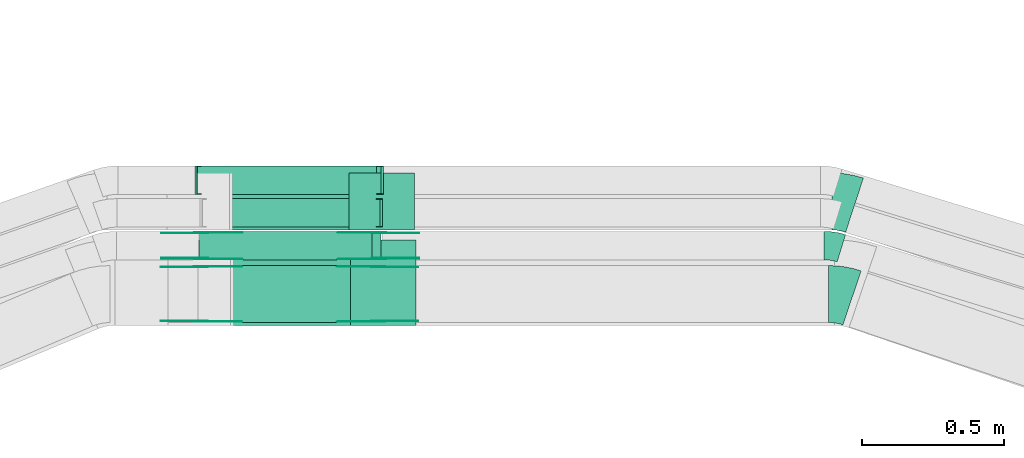
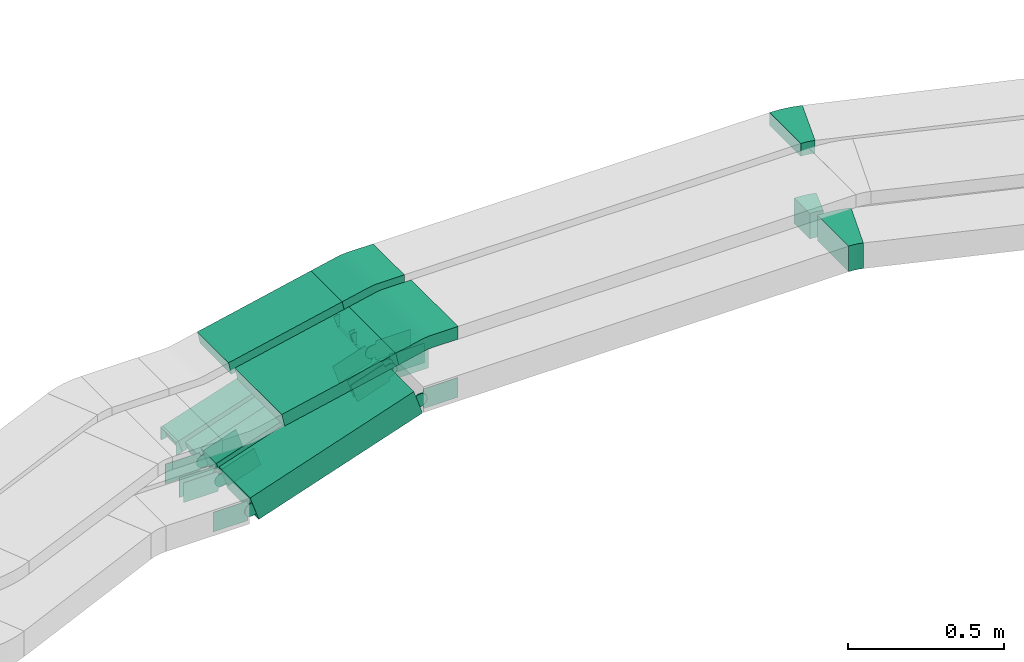
# One storey, part 10 of 31: 24 flow fittings, 6 flow segments.
"""IFC2X3 building model written with IfcOpenShell, lengths in millimetres."""

from ifc_helpers import new_model, entity, si_unit, converted_unit, derived_unit, direction, frame, frame_2d, origin, origin_2d_with_axis, place, context, subcontext, project, spatial, polyline, circle_curve, parameter, trimmed, segment, composite_curve, rectangle, outline, extrude, faceted_brep, source, transform, mapped, material, type_object, type_shapes, element, save


model = new_model("IFC2X3")

# Units and contexts
model_context = context("Model", 3, precision=0.01, world=origin(), true_north=direction((6.12303176911189e-17, 1.0)))
body_context = subcontext(model_context, "Body", "Model", "MODEL_VIEW")
ifc_project = project(units=[si_unit("LENGTHUNIT", "METRE", prefix="MILLI"), si_unit("AREAUNIT", "SQUARE_METRE"), si_unit("VOLUMEUNIT", "CUBIC_METRE"), converted_unit("PLANEANGLEUNIT", "DEGREE", entity("IfcRatioMeasure", 0.0174532925199433), si_unit("PLANEANGLEUNIT", "RADIAN"), dimensions=[0, 0, 0, 0, 0, 0, 0]), si_unit("MASSUNIT", "GRAM", prefix="KILO"), derived_unit("MASSDENSITYUNIT", [(si_unit("MASSUNIT", "GRAM", prefix="KILO"), 1), (si_unit("LENGTHUNIT", "METRE"), -3)]), derived_unit("MOMENTOFINERTIAUNIT", [(si_unit("LENGTHUNIT", "METRE"), 4)]), si_unit("TIMEUNIT", "SECOND"), si_unit("FREQUENCYUNIT", "HERTZ"), si_unit("THERMODYNAMICTEMPERATUREUNIT", "DEGREE_CELSIUS"), derived_unit("THERMALTRANSMITTANCEUNIT", [(si_unit("MASSUNIT", "GRAM", prefix="KILO"), 1), (si_unit("THERMODYNAMICTEMPERATUREUNIT", "KELVIN"), -1), (si_unit("TIMEUNIT", "SECOND"), -3)]), derived_unit("VOLUMETRICFLOWRATEUNIT", [(si_unit("LENGTHUNIT", "METRE"), 3), (si_unit("TIMEUNIT", "SECOND"), -1)]), derived_unit("MASSFLOWRATEUNIT", [(si_unit("MASSUNIT", "GRAM", prefix="KILO"), 1), (si_unit("TIMEUNIT", "SECOND"), -1)]), derived_unit("ROTATIONALFREQUENCYUNIT", [(si_unit("TIMEUNIT", "SECOND"), -1)]), si_unit("ELECTRICCURRENTUNIT", "AMPERE"), si_unit("ELECTRICVOLTAGEUNIT", "VOLT"), si_unit("POWERUNIT", "WATT"), si_unit("FORCEUNIT", "NEWTON", prefix="KILO"), si_unit("ILLUMINANCEUNIT", "LUX"), si_unit("LUMINOUSFLUXUNIT", "LUMEN"), si_unit("LUMINOUSINTENSITYUNIT", "CANDELA"), derived_unit("USERDEFINED", [(si_unit("MASSUNIT", "GRAM", prefix="KILO"), -1), (si_unit("LENGTHUNIT", "METRE"), -2), (si_unit("TIMEUNIT", "SECOND"), 3), (si_unit("LUMINOUSFLUXUNIT", "LUMEN"), 1)]), derived_unit("LINEARVELOCITYUNIT", [(si_unit("LENGTHUNIT", "METRE"), 1), (si_unit("TIMEUNIT", "SECOND"), -1)]), si_unit("PRESSUREUNIT", "PASCAL"), derived_unit("USERDEFINED", [(si_unit("LENGTHUNIT", "METRE"), -2), (si_unit("MASSUNIT", "GRAM", prefix="KILO"), 1), (si_unit("TIMEUNIT", "SECOND"), -2)]), derived_unit("LINEARFORCEUNIT", [(si_unit("MASSUNIT", "GRAM", prefix="KILO"), 1), (si_unit("LENGTHUNIT", "METRE"), 1), (si_unit("TIMEUNIT", "SECOND"), -2), (si_unit("LENGTHUNIT", "METRE"), -1)]), derived_unit("PLANARFORCEUNIT", [(si_unit("MASSUNIT", "GRAM", prefix="KILO"), 1), (si_unit("LENGTHUNIT", "METRE"), 1), (si_unit("TIMEUNIT", "SECOND"), -2), (si_unit("LENGTHUNIT", "METRE"), -2)])], contexts=[model_context])

# Site, building, storey
site_placement = place(None, frame((0.0, -0.00077364408347762, 0.0)))
site = spatial("IfcSite", under=ifc_project, at=site_placement, CompositionType="ELEMENT")
building_placement = place(site_placement, origin())
building = spatial("IfcBuilding", under=site, at=building_placement, CompositionType="ELEMENT")
storey_placement = place(building_placement, frame((0.0, 0.0, 15900.0)))
storey = spatial("IfcBuildingStorey", under=building, at=storey_placement, CompositionType="ELEMENT", Elevation=15900.0)

# Flow segments
cable_carrier_segment_type = type_object("IfcCableCarrierSegmentType", PredefinedType="CABLETRAYSEGMENT")
flow_segment_1_placement = place(storey_placement, frame((34367.8616765171, 8525.14880665488, 2844.71853749303)))
element("IfcFlowSegment", 1, at=flow_segment_1_placement, inside=storey, type_object=cable_carrier_segment_type, context=body_context, shape_type="SweptSolid", body=[
    extrude(rectangle(XDim=50.0000000000015, YDim=300.000000000001, at=frame_2d((-1.05693231944315e-12, 0.0), x_axis=(1.0, 0.0))), frame((5.31223764810624, 150.0, 24.4290837153194), z_axis=(0.977163348612744, 0.0, 0.212489505924243), x_axis=(-0.212489505924243, 0.0, 0.977163348612744)), (0.0, 0.0, 1.0), 431.573113149383),
])
flow_segment_2_placement = place(storey_placement, frame((34257.0178499815, 8534.96624585791, 2505.75422577763)))
element("IfcFlowSegment", 2, at=flow_segment_2_placement, inside=storey, type_object=cable_carrier_segment_type, context=body_context, shape_type="SweptSolid", body=[
    extrude(rectangle(XDim=100.000000000002, YDim=200.0, at=frame_2d((-1.02673425317334e-12, 0.0), x_axis=(1.0, 0.0))), frame((15.9523830264447, 100.0, 47.3869335975389), z_axis=(0.947738671950759, 0.0, 0.319047660528974), x_axis=(-0.319047660528974, 0.0, 0.947738671950759)), (0.0, 0.0, 1.0), 638.51802239172),
])
flow_segment_3_placement = place(storey_placement, frame((34364.2320277853, 8860.14880665488, 2844.76627550106)))
element("IfcFlowSegment", 3, at=flow_segment_3_placement, inside=storey, type_object=cable_carrier_segment_type, context=body_context, shape_type="SweptSolid", body=[
    extrude(rectangle(XDim=50.0000000000002, YDim=200.0, at=origin_2d_with_axis()), frame((5.32226202099544, 100.0, 24.4269017065186), z_axis=(0.97707606826074, 0.0, 0.212890480839644), x_axis=(-0.212890480839644, 0.0, 0.97707606826074)), (0.0, 0.0, 1.0), 430.332278002831),
])
flow_segment_4_placement = place(storey_placement, frame((34259.2951220946, 8755.14880665489, 2505.75422577764)))
element("IfcFlowSegment", 4, at=flow_segment_4_placement, inside=storey, type_object=cable_carrier_segment_type, context=body_context, shape_type="SweptSolid", body=[
    extrude(rectangle(XDim=100.0, YDim=99.9999999999989, at=frame_2d((1.02318153949454e-12, 0.0), x_axis=(1.0, 0.0))), frame((15.952383026449, 50.0, 47.3869335975389), z_axis=(0.947738671950757, 0.0, 0.319047660528981), x_axis=(-0.319047660528981, 0.0, 0.947738671950757)), (0.0, 0.0, 1.0), 638.518022391706),
])
flow_segment_5_placement = place(storey_placement, frame((34268.2725111262, 8870.14880665489, 2503.91959960369)))
element("IfcFlowSegment", 5, at=flow_segment_5_placement, inside=storey, type_object=cable_carrier_segment_type, context=body_context, shape_type="SweptSolid", body=[
    extrude(rectangle(XDim=50.0000000000011, YDim=100.000000000001, at=frame_2d((-2.05169214950729e-12, 0.0), x_axis=(1.0, 0.0))), frame((7.97619151322019, 50.0, 23.6934667987695), z_axis=(0.947738671950759, 0.0, 0.319047660528974), x_axis=(-0.319047660528974, 0.0, 0.947738671950759)), (0.0, 0.0, 1.0), 643.826105191566),
])
flow_segment_6_placement = place(storey_placement, frame((34251.0843896599, 8985.14880665487, 2503.6972847833)))
element("IfcFlowSegment", 6, at=flow_segment_6_placement, inside=storey, type_object=cable_carrier_segment_type, context=body_context, shape_type="SweptSolid", body=[
    extrude(rectangle(XDim=49.9999999999993, YDim=100.000000000001, at=origin_2d_with_axis()), frame((7.75258238500092, 50.0, 23.7675717389021), z_axis=(0.950702869556012, 0.0, 0.310103295400041), x_axis=(-0.310103295400041, 0.0, 0.950702869556012)), (0.0, 0.0, 1.0), 663.238349794011),
])

# Flow fittings
ifc_material_1 = material()
cable_carrier_fitting_type_1 = type_object("IfcCableCarrierFittingType", Name="470_DKC_S5_Variable Angle Elbow 0-45:-", PredefinedType="NOTDEFINED", material=ifc_material_1)
shared_shape_1 = source(origin(), body_context, "Body", "SweptSolid", [
    extrude(outline(composite_curve([segment(polyline([(-40.9478177132419, -106.639542282513), (-39.9478177132405, -106.639542282513)]), True, "CONTINUOUS"), segment(trimmed(circle_curve(frame_2d((-39.9478177132411, 243.360457717487), x_axis=(0.0, -1.0)), 350.0), [parameter(0.0)], [parameter(18.6440270035289)], True, "PARAMETER"), True, "CONTINUOUS"), segment(polyline([(71.9428057581219, -88.2726051384194), (72.8903287948528, -87.9529176427871)]), True, "CONTINUOUS"), segment(polyline([(72.8903287948527, -87.9529176427871), (8.95282966836023, 101.551689703445)]), True, "CONTINUOUS"), segment(polyline([(8.95282966836026, 101.551689703445), (8.00530663162875, 101.232002207813)]), True, "CONTINUOUS"), segment(trimmed(circle_curve(frame_2d((-39.9478177132411, 243.360457717487), x_axis=(0.0, -1.0)), 150.0), [parameter(0.0)], [parameter(18.6440270035289)], True, "PARAMETER"), False, "CONTINUOUS"), segment(polyline([(-39.9478177132405, 93.360457717487), (-40.9478177132419, 93.360457717487)]), True, "CONTINUOUS"), segment(polyline([(-40.9478177132419, 93.360457717487), (-40.9478177132419, -106.639542282513)]), True, "CONTINUOUS")], self_intersect=False)), frame((-1.08988628344333, 6.63954228250484, -50.0)), (0.0, 0.0, 1.0), 100.0),
])
type_shapes(cable_carrier_fitting_type_1, [shared_shape_1])
flow_fitting_1_placement = place(storey_placement, frame((36511.1900385657, 8634.96624585789, 2760.0), z_axis=(0.0, 0.0, 1.0), x_axis=(-0.947523036731155, 0.319687495632485, 0.0)))
element("IfcFlowFitting", 7, at=flow_fitting_1_placement, inside=storey, type_object=cable_carrier_fitting_type_1, material=ifc_material_1, Name="470_DKC_S5_Variable Angle Elbow 0-45:-", ObjectType="470_DKC_S5_Variable Angle Elbow 0-45:-", context=body_context, shape_type="MappedRepresentation", body=[
    mapped(shared_shape_1, transform((0.0, 0.0, 0.0), scale=1.0)),
])
cable_carrier_fitting_type_2 = type_object("IfcCableCarrierFittingType", Name="470_DKC_S5_Variable Angle Elbow 0-45:-", PredefinedType="NOTDEFINED", material=ifc_material_1)
shared_shape_2 = source(origin(), body_context, "Body", "SweptSolid", [
    extrude(outline(composite_curve([segment(polyline([(-39.9843642587752, -106.316693839402), (-38.9843642587738, -106.316693839402)]), True, "CONTINUOUS"), segment(trimmed(circle_curve(frame_2d((-38.9843642587684, 243.683306160597), x_axis=(0.0, -1.0)), 350.0), [parameter(0.0)], [parameter(18.1782774573338)], True, "PARAMETER"), True, "CONTINUOUS"), segment(polyline([(70.2067923866629, -88.8483334023663), (71.1568827854141, -88.5363586690937)]), True, "CONTINUOUS"), segment(polyline([(71.1568827854141, -88.5363586690937), (8.76193613088225, 101.481721081171)]), True, "CONTINUOUS"), segment(polyline([(8.76193613088223, 101.481721081171), (7.81184573213071, 101.169746347899)]), True, "CONTINUOUS"), segment(trimmed(circle_curve(frame_2d((-38.9843642587684, 243.683306160597), x_axis=(0.0, -1.0)), 150.0), [parameter(0.0)], [parameter(18.1782774573338)], True, "PARAMETER"), False, "CONTINUOUS"), segment(polyline([(-38.9843642587704, 93.6833061605973), (-39.9843642587718, 93.6833061605974)]), True, "CONTINUOUS"), segment(polyline([(-39.9843642587718, 93.6833061605974), (-39.9843642587752, -106.316693839402)]), True, "CONTINUOUS")], self_intersect=False)), frame((-1.01054231996523, 6.31669383939512, -25.0)), (0.0, 0.0, 1.0), 50.0000000000005),
])
type_shapes(cable_carrier_fitting_type_2, [shared_shape_2])
flow_fitting_2_placement = place(storey_placement, frame((36520.9237386279, 8960.14880665485, 2985.0), z_axis=(0.0, 0.0, 1.0), x_axis=(-0.950090398751314, 0.311974733272694, 0.0)))
element("IfcFlowFitting", 8, at=flow_fitting_2_placement, inside=storey, type_object=cable_carrier_fitting_type_2, material=ifc_material_1, Name="470_DKC_S5_Variable Angle Elbow 0-45:-", ObjectType="470_DKC_S5_Variable Angle Elbow 0-45:-", context=body_context, shape_type="MappedRepresentation", body=[
    mapped(shared_shape_2, transform((0.0, 0.0, 0.0), scale=1.0)),
])
cable_carrier_fitting_type_3 = type_object("IfcCableCarrierFittingType", Name="470_DKC_S5_Variable Angle Elbow 0-45:-", PredefinedType="NOTDEFINED", material=ifc_material_1)
shared_shape_3 = source(origin(), body_context, "Body", "SweptSolid", [
    extrude(outline(composite_curve([segment(polyline([(-30.3827359067061, -54.4910294125029), (-29.3827359067048, -54.4910294125029)]), True, "CONTINUOUS"), segment(trimmed(circle_curve(frame_2d((-29.3827359067073, 195.508970587497), x_axis=(0.0, -1.0)), 250.0), [parameter(0.0)], [parameter(17.0938540056396)], True, "PARAMETER"), True, "CONTINUOUS"), segment(polyline([(44.1017135160781, -43.4471670048026), (45.0575380664473, -43.1532292071114)]), True, "CONTINUOUS"), segment(polyline([(45.0575380664473, -43.1532292071115), (15.6637582973331, 52.4292258298083)]), True, "CONTINUOUS"), segment(polyline([(15.6637582973331, 52.4292258298083), (14.7079337469639, 52.1352880321172)]), True, "CONTINUOUS"), segment(trimmed(circle_curve(frame_2d((-29.3827359067073, 195.508970587497), x_axis=(0.0, -1.0)), 150.0), [parameter(0.0)], [parameter(17.0938540056396)], True, "PARAMETER"), False, "CONTINUOUS"), segment(polyline([(-29.3827359067056, 45.508970587497), (-30.3827359067069, 45.508970587497)]), True, "CONTINUOUS"), segment(polyline([(-30.3827359067069, 45.508970587497), (-30.3827359067061, -54.4910294125029)]), True, "CONTINUOUS")], self_intersect=False)), frame((-0.674949751811232, 4.49102941249455, -50.0)), (0.0, 0.0, 1.0), 100.0),
])
type_shapes(cable_carrier_fitting_type_3, [shared_shape_3])
flow_fitting_3_placement = place(storey_placement, frame((36483.8641502779, 8805.14880665485, 2760.0), z_axis=(0.0, 0.0, 1.0), x_axis=(-0.955824550369197, 0.293937797691149, 0.0)))
element("IfcFlowFitting", 9, at=flow_fitting_3_placement, inside=storey, type_object=cable_carrier_fitting_type_3, material=ifc_material_1, Name="470_DKC_S5_Variable Angle Elbow 0-45:-", ObjectType="470_DKC_S5_Variable Angle Elbow 0-45:-", context=body_context, shape_type="MappedRepresentation", body=[
    mapped(shared_shape_3, transform((0.0, 0.0, 0.0), scale=1.0)),
])
cable_carrier_fitting_type_4 = type_object("IfcCableCarrierFittingType", Name="470_DKC_S5_CD 90 external vertical angle:-", PredefinedType="NOTDEFINED", material=ifc_material_1)
shared_shape_4 = source(origin(), body_context, "Body", "SweptSolid", [
    extrude(outline(composite_curve([segment(polyline([(-112.891439064344, -31.9789171718148), (-16.9828263503482, -31.9789171718148)]), True, "CONTINUOUS"), segment(trimmed(circle_curve(frame_2d((-16.9828263503485, 158.021082828184), x_axis=(0.0, -1.0)), 189.999999999999), [parameter(0.0)], [parameter(12.2682836771792)], True, "PARAMETER"), True, "CONTINUOUS"), segment(polyline([(23.3901797752441, -27.6399534082391), (117.108560935656, -7.2603796787696)]), True, "CONTINUOUS"), segment(polyline([(117.108560935656, -7.26037967876959), (106.484085639448, 41.5977877518686)]), True, "CONTINUOUS"), segment(polyline([(106.484085639448, 41.5977877518686), (12.7657044790354, 21.2182140223991)]), True, "CONTINUOUS"), segment(trimmed(circle_curve(frame_2d((-16.9828263503485, 158.021082828184), x_axis=(0.0, -1.0)), 139.999999999999), [parameter(0.0)], [parameter(12.2682836771792)], True, "PARAMETER"), False, "CONTINUOUS"), segment(polyline([(-16.9828263503482, 18.0210828281855), (-112.891439064344, 18.0210828281855)]), True, "CONTINUOUS"), segment(polyline([(-112.891439064344, 18.0210828281855), (-112.891439064344, -31.9789171718148)]), True, "CONTINUOUS")], self_intersect=False)), frame((-0.750037503349171, 6.97891717180758, -150.0)), (0.0, 0.0, 1.0), 300.0),
])
type_shapes(cable_carrier_fitting_type_4, [shared_shape_4])
flow_fitting_4_placement = place(storey_placement, frame((34905.9376283657, 8675.14880665488, 2985.0), z_axis=(0.0, -1.0, 0.0), x_axis=(-1.0, 0.0, 0.0)))
element("IfcFlowFitting", 10, at=flow_fitting_4_placement, inside=storey, type_object=cable_carrier_fitting_type_4, material=ifc_material_1, Name="470_DKC_S5_CD 90 external vertical angle:-", ObjectType="470_DKC_S5_CD 90 external vertical angle:-", context=body_context, shape_type="MappedRepresentation", body=[
    mapped(shared_shape_4, transform((0.0, 0.0, 0.0), scale=1.0)),
])
cable_carrier_fitting_type_5 = type_object("IfcCableCarrierFittingType", Name="470_DKC_S5_CD 90 external vertical angle:-", PredefinedType="NOTDEFINED", material=ifc_material_1)
shared_shape_5 = source(origin(), body_context, "Body", "SweptSolid", [
    extrude(outline(composite_curve([segment(polyline([(-112.888323037853, -31.9939064861405), (-17.0140106209194, -31.9939064861405)]), True, "CONTINUOUS"), segment(trimmed(circle_curve(frame_2d((-17.0140106209197, 158.006093513858), x_axis=(0.0, -1.0)), 189.999999999999), [parameter(0.0)], [parameter(12.2917958116951)], True, "PARAMETER"), True, "CONTINUOUS"), segment(polyline([(23.4351807386065, -27.6383594556824), (117.111676962147, -7.22763098507425)]), True, "CONTINUOUS"), segment(polyline([(117.111676962147, -7.22763098507427), (106.467152920166, 41.6261724279633)]), True, "CONTINUOUS"), segment(polyline([(106.467152920166, 41.6261724279633), (12.7906566966258, 21.2154439573552)]), True, "CONTINUOUS"), segment(trimmed(circle_curve(frame_2d((-17.0140106209197, 158.006093513858), x_axis=(0.0, -1.0)), 139.999999999999), [parameter(0.0)], [parameter(12.2917958116951)], True, "PARAMETER"), False, "CONTINUOUS"), segment(polyline([(-17.0140106209194, 18.0060935138597), (-112.888323037853, 18.0060935138597)]), True, "CONTINUOUS"), segment(polyline([(-112.888323037853, 18.0060935138597), (-112.888323037853, -31.9939064861405)]), True, "CONTINUOUS")], self_intersect=False)), frame((-0.753100064619125, 6.99390648613325, -100.0)), (0.0, 0.0, 1.0), 200.0),
])
type_shapes(cable_carrier_fitting_type_5, [shared_shape_5])
flow_fitting_5_placement = place(storey_placement, frame((34901.0579749195, 8960.14880665488, 2985.0), z_axis=(0.0, -1.0, 0.0), x_axis=(-1.0, 0.0, 0.0)))
element("IfcFlowFitting", 11, at=flow_fitting_5_placement, inside=storey, type_object=cable_carrier_fitting_type_5, material=ifc_material_1, Name="470_DKC_S5_CD 90 external vertical angle:-", ObjectType="470_DKC_S5_CD 90 external vertical angle:-", context=body_context, shape_type="MappedRepresentation", body=[
    mapped(shared_shape_5, transform((0.0, 0.0, 0.0), scale=1.0)),
])
cable_carrier_fitting_type_6 = type_object("IfcCableCarrierFittingType", PredefinedType="NOTDEFINED", material=ifc_material_1)
shared_shape_6 = source(origin(), body_context, "Body", "Brep", [
    faceted_brep([(-8.19020706225814, 25.0, 50.0), (-8.19020706225814, 25.0, -50.0), (-8.1902070622583, -25.0, -50.0), (-8.1902070622583, -25.0, -47.4600000101565), (-8.19020706225814, 22.46000001016, -47.4600000101565), (-8.19020706225814, 22.46000001016, 47.4600000101635), (-8.1902070622583, -25.0, 47.4600000101635), (-8.1902070622583, -25.0, 50.0), (-0.214015549035263, 26.30653320123, 50.0), (15.7383674774103, -21.080400396309, 50.0), (15.7383674774103, -21.080400396309, 47.4600000101635), (0.596365505466648, 23.8992769841041, 47.4600000101635), (0.596365505466639, 23.8992769841041, -47.4600000101565), (15.7383674774103, -21.080400396309, -47.4600000101565), (15.7383674774103, -21.080400396309, -50.0), (-0.21401554903526, 26.30653320123, -50.0), (-4.09510353112875, 25.0, 50.0), (-4.09510353112883, 25.0, -50.0), (4.09510353112973, -25.0, -50.0), (4.09510353112973, -25.0, -47.4600000101565), (-3.67904101403035, 22.46000001016, -47.4600000101565), (-3.67904101403035, 22.46000001016, 47.4600000101635), (4.09510353112973, -25.0, 47.4600000101635), (4.09510353112973, -25.0, 50.0)], [[[0, 1, 2, 3, 4, 5, 6, 7]], [[8, 9, 10, 11, 12, 13, 14, 15]], [[1, 0, 16, 17]], [[2, 1, 17, 15, 14, 18]], [[3, 2, 18, 19]], [[4, 3, 19, 13, 12, 20]], [[5, 4, 20, 21]], [[6, 5, 21, 11, 10, 22]], [[7, 6, 22, 23]], [[0, 7, 23, 9, 8, 16]], [[17, 16, 8, 15]], [[19, 18, 14, 13]], [[21, 20, 12, 11]], [[23, 22, 10, 9]]]),
])
type_shapes(cable_carrier_fitting_type_6, [shared_shape_6])
flow_fitting_6_placement = place(storey_placement, frame((34894.1897765051, 8920.1488066549, 2735.63734545371), z_axis=(0.0, -1.0, 0.0), x_axis=(-1.0, 0.0, 0.0)))
element("IfcFlowFitting", 12, at=flow_fitting_6_placement, inside=storey, type_object=cable_carrier_fitting_type_6, material=ifc_material_1, context=body_context, shape_type="MappedRepresentation", body=[
    mapped(shared_shape_6, transform((0.0, 0.0, 0.0), scale=1.0)),
])
cable_carrier_fitting_type_7 = type_object("IfcCableCarrierFittingType", PredefinedType="NOTDEFINED", material=ifc_material_1)
shared_shape_7 = source(origin(), body_context, "Body", "Brep", [
    faceted_brep([(-7.94850154371752, 25.0, 50.0), (-7.94850154371752, 25.0, -50.0), (-7.94850154371768, -25.0, -50.0), (-7.94850154371768, -25.0, -47.4600000101565), (-7.94850154371752, 22.46000001016, -47.4600000101565), (-7.94850154371752, 22.46000001016, 47.4600000101635), (-7.94850154371768, -25.0, 47.4600000101635), (-7.94850154371768, -25.0, 50.0), (-0.195919158716847, 26.2324282610991, 50.0), (15.3092456112844, -21.3027152167017, 50.0), (15.3092456112844, -21.3027152167017, 47.4600000101635), (0.591743208448575, 23.817642982086, 47.4600000101635), (0.59174320844857, 23.817642982086, -47.4600000101565), (15.3092456112844, -21.3027152167017, -47.4600000101565), (15.3092456112844, -21.3027152167017, -50.0), (-0.19591915871684, 26.2324282610991, -50.0), (-3.97425077185847, 25.0, 50.0), (-3.97425077185854, 25.0, -50.0), (3.97425077185945, -25.0, -50.0), (3.97425077185945, -25.0, -47.4600000101565), (-3.57046689505281, 22.46000001016, -47.4600000101565), (-3.57046689505281, 22.46000001016, 47.4600000101635), (3.97425077185945, -25.0, 47.4600000101635), (3.97425077185945, -25.0, 50.0)], [[[0, 1, 2, 3, 4, 5, 6, 7]], [[8, 9, 10, 11, 12, 13, 14, 15]], [[1, 0, 16, 17]], [[2, 1, 17, 15, 14, 18]], [[3, 2, 18, 19]], [[4, 3, 19, 13, 12, 20]], [[5, 4, 20, 21]], [[6, 5, 21, 11, 10, 22]], [[7, 6, 22, 23]], [[0, 7, 23, 9, 8, 16]], [[17, 16, 8, 15]], [[19, 18, 14, 13]], [[21, 20, 12, 11]], [[23, 22, 10, 9]]]),
])
type_shapes(cable_carrier_fitting_type_7, [shared_shape_7])
for number, where, z_axis, x_axis in (
    (13, (34896.9362376199, 9035.14880665487, 2735.60211095118), (0.0, -1.0, 0.0), (-1.0, 0.0, 0.0)),
    (14, (34251.2803088186, 9035.14880665487, 2525.0), (0.0, -1.0, 0.0), (1.0, 0.0, 0.0)),
):
    element("IfcFlowFitting", number, at=place(storey_placement, frame(where, z_axis=z_axis, x_axis=x_axis)), inside=storey, type_object=cable_carrier_fitting_type_7, material=ifc_material_1, context=body_context, shape_type="MappedRepresentation", body=[
        mapped(shared_shape_7, transform((0.0, 0.0, 0.0), scale=1.0)),
    ])
ifc_material_2 = material(Name="G")
cable_carrier_fitting_type_8 = type_object("IfcCableCarrierFittingType", PredefinedType="NOTDEFINED", material=ifc_material_2)
shared_shape_8 = source(origin(), body_context, "Body", "SweptSolid", [
    extrude(outline(composite_curve([segment(trimmed(circle_curve(frame_2d((-41.4651162790697, 0.0), x_axis=(1.0, 0.0)), 25.0), [parameter(90.0000000000007)], [parameter(270.0)], True, "PARAMETER"), True, "CONTINUOUS"), segment(polyline([(-41.4651162790697, -25.0), (-29.9651162790697, -25.0)]), True, "CONTINUOUS"), segment(polyline([(-29.9651162790697, -25.0), (-28.1046511627907, -38.5)]), True, "CONTINUOUS"), segment(polyline([(-28.1046511627907, -38.5), (99.5348837209303, -38.5)]), True, "CONTINUOUS"), segment(polyline([(99.5348837209303, -38.5), (99.5348837209303, 38.5)]), True, "CONTINUOUS"), segment(polyline([(99.5348837209303, 38.5), (-28.1046511627907, 38.5)]), True, "CONTINUOUS"), segment(polyline([(-28.1046511627907, 38.5), (-29.9651162790697, 25.0)]), True, "CONTINUOUS"), segment(polyline([(-29.9651162790697, 25.0), (-41.46511627907, 25.0)]), True, "CONTINUOUS")], self_intersect=False)), frame((41.4651162790697, 0.0, 0.0), z_axis=(0.0, 0.0, -1.0), x_axis=(1.0, 0.0, 0.0)), (0.0, 0.0, -1.0), 2.0),
])
type_shapes(cable_carrier_fitting_type_8, [shared_shape_8])
for number, where, z_axis, x_axis in (
    (15, (34889.7266163925, 8759.68880664473, 2760.0), (0.0, -1.0, 0.0), (-0.947738671950754, 0.0, -0.319047660528989)),
    (16, (34265.9166164078, 8759.68880664473, 2550.0), (0.0, -1.0, 0.0), (0.947738671950754, 0.0, 0.319047660528989)),
    (17, (34887.4493442794, 8539.50624584775, 2760.0), (0.0, -1.0, 0.0), (-0.947738671950754, 0.0, -0.319047660528989)),
    (18, (34263.6393442946, 8539.50624584776, 2550.0), (0.0, -1.0, 0.0), (0.947738671950754, 0.0, 0.319047660528989)),
):
    element("IfcFlowFitting", number, at=place(storey_placement, frame(where, z_axis=z_axis, x_axis=x_axis)), inside=storey, type_object=cable_carrier_fitting_type_8, material=ifc_material_2, context=body_context, shape_type="MappedRepresentation", body=[
        mapped(shared_shape_8, transform((0.0, 0.0, 0.0), scale=1.0)),
    ])
cable_carrier_fitting_type_9 = type_object("IfcCableCarrierFittingType", PredefinedType="NOTDEFINED", material=ifc_material_2)
shared_shape_9 = source(origin(), body_context, "Body", "SweptSolid", [
    extrude(outline(composite_curve([segment(trimmed(circle_curve(frame_2d((-41.4651162790697, 0.0), x_axis=(1.0, 0.0)), 25.0), [parameter(90.0000000000007)], [parameter(270.0)], True, "PARAMETER"), True, "CONTINUOUS"), segment(polyline([(-41.4651162790697, -25.0), (-29.9651162790697, -25.0)]), True, "CONTINUOUS"), segment(polyline([(-29.9651162790697, -25.0), (-28.1046511627907, -38.5)]), True, "CONTINUOUS"), segment(polyline([(-28.1046511627907, -38.5), (99.5348837209303, -38.5)]), True, "CONTINUOUS"), segment(polyline([(99.5348837209303, -38.5), (99.5348837209303, 38.5)]), True, "CONTINUOUS"), segment(polyline([(99.5348837209303, 38.5), (-28.1046511627907, 38.5)]), True, "CONTINUOUS"), segment(polyline([(-28.1046511627907, 38.5), (-29.9651162790697, 25.0)]), True, "CONTINUOUS"), segment(polyline([(-29.9651162790697, 25.0), (-41.46511627907, 25.0)]), True, "CONTINUOUS")], self_intersect=False)), frame((41.4651162790697, 0.0, 0.0)), (0.0, 0.0, 1.0), 2.0),
])
type_shapes(cable_carrier_fitting_type_9, [shared_shape_9])
for number, where, z_axis, x_axis in (
    (19, (34889.7266163925, 8850.60880666505, 2760.0), (0.0, 1.0, 0.0), (-0.947738671950754, 0.0, -0.319047660528989)),
    (20, (34265.9166164078, 8850.60880666505, 2550.0), (0.0, 1.0, 0.0), (0.947738671950754, 0.0, 0.319047660528989)),
    (21, (34887.4493442794, 8730.42624586807, 2760.0), (0.0, 1.0, 0.0), (-0.947738671950754, 0.0, -0.319047660528989)),
    (22, (34263.6393442946, 8730.42624586808, 2550.0), (0.0, 1.0, 0.0), (0.947738671950754, 0.0, 0.319047660528989)),
):
    element("IfcFlowFitting", number, at=place(storey_placement, frame(where, z_axis=z_axis, x_axis=x_axis)), inside=storey, type_object=cable_carrier_fitting_type_9, material=ifc_material_2, context=body_context, shape_type="MappedRepresentation", body=[
        mapped(shared_shape_9, transform((0.0, 0.0, 0.0), scale=1.0)),
    ])
cable_carrier_fitting_type_10 = type_object("IfcCableCarrierFittingType", PredefinedType="NOTDEFINED", material=ifc_material_2)
shared_shape_10 = source(origin(), body_context, "Body", "SweptSolid", [
    extrude(outline(composite_curve([segment(trimmed(circle_curve(frame_2d((-41.4651162790697, 0.0), x_axis=(1.0, 0.0)), 25.0), [parameter(90.0000000000007)], [parameter(270.0)], True, "PARAMETER"), True, "CONTINUOUS"), segment(polyline([(-41.4651162790697, -25.0), (-29.9651162790697, -25.0)]), True, "CONTINUOUS"), segment(polyline([(-29.9651162790697, -25.0), (-28.1046511627907, -38.5)]), True, "CONTINUOUS"), segment(polyline([(-28.1046511627907, -38.5), (99.5348837209303, -38.5)]), True, "CONTINUOUS"), segment(polyline([(99.5348837209303, -38.5), (99.5348837209303, 38.5)]), True, "CONTINUOUS"), segment(polyline([(99.5348837209303, 38.5), (-28.1046511627907, 38.5)]), True, "CONTINUOUS"), segment(polyline([(-28.1046511627907, 38.5), (-29.9651162790697, 25.0)]), True, "CONTINUOUS"), segment(polyline([(-29.9651162790697, 25.0), (-41.46511627907, 25.0)]), True, "CONTINUOUS")], self_intersect=False)), frame((41.4651162790697, 0.0, 0.0), z_axis=(0.0, 0.0, -1.0), x_axis=(1.0, 0.0, 0.0)), (0.0, 0.0, -1.0), 2.0),
])
type_shapes(cable_carrier_fitting_type_10, [shared_shape_10])
for number, where, z_axis, x_axis in (
    (23, (34889.7266163925, 8848.60880666505, 2760.0), (0.0, 1.0, 0.0), (1.0, 0.0, 0.0)),
    (24, (34265.9166164078, 8848.60880666505, 2550.0), (0.0, 1.0, 0.0), (-1.0, 0.0, 0.0)),
    (25, (34887.4493442793, 8728.42624586807, 2760.0), (0.0, 1.0, 0.0), (1.0, 0.0, 0.0)),
    (26, (34263.6393442946, 8728.42624586808, 2550.0), (0.0, 1.0, 0.0), (-1.0, 0.0, 0.0)),
):
    element("IfcFlowFitting", number, at=place(storey_placement, frame(where, z_axis=z_axis, x_axis=x_axis)), inside=storey, type_object=cable_carrier_fitting_type_10, material=ifc_material_2, context=body_context, shape_type="MappedRepresentation", body=[
        mapped(shared_shape_10, transform((0.0, 0.0, 0.0), scale=1.0)),
    ])
cable_carrier_fitting_type_11 = type_object("IfcCableCarrierFittingType", PredefinedType="NOTDEFINED", material=ifc_material_2)
shared_shape_11 = source(origin(), body_context, "Body", "SweptSolid", [
    extrude(outline(composite_curve([segment(trimmed(circle_curve(frame_2d((-41.4651162790697, 0.0), x_axis=(1.0, 0.0)), 25.0), [parameter(90.0000000000007)], [parameter(270.0)], True, "PARAMETER"), True, "CONTINUOUS"), segment(polyline([(-41.4651162790697, -25.0), (-29.9651162790697, -25.0)]), True, "CONTINUOUS"), segment(polyline([(-29.9651162790697, -25.0), (-28.1046511627907, -38.5)]), True, "CONTINUOUS"), segment(polyline([(-28.1046511627907, -38.5), (99.5348837209303, -38.5)]), True, "CONTINUOUS"), segment(polyline([(99.5348837209303, -38.5), (99.5348837209303, 38.5)]), True, "CONTINUOUS"), segment(polyline([(99.5348837209303, 38.5), (-28.1046511627907, 38.5)]), True, "CONTINUOUS"), segment(polyline([(-28.1046511627907, 38.5), (-29.9651162790697, 25.0)]), True, "CONTINUOUS"), segment(polyline([(-29.9651162790697, 25.0), (-41.46511627907, 25.0)]), True, "CONTINUOUS")], self_intersect=False)), frame((41.4651162790697, 0.0, 0.0)), (0.0, 0.0, 1.0), 2.0),
])
type_shapes(cable_carrier_fitting_type_11, [shared_shape_11])
for number, where, z_axis, x_axis in (
    (27, (34889.7266163925, 8761.68880664473, 2760.0), (0.0, -1.0, 0.0), (1.0, 0.0, 0.0)),
    (28, (34265.9166164078, 8761.68880664473, 2550.0), (0.0, -1.0, 0.0), (-1.0, 0.0, 0.0)),
    (29, (34887.4493442793, 8541.50624584776, 2760.0), (0.0, -1.0, 0.0), (1.0, 0.0, 0.0)),
    (30, (34263.6393442946, 8541.50624584776, 2550.0), (0.0, -1.0, 0.0), (-1.0, 0.0, 0.0)),
):
    element("IfcFlowFitting", number, at=place(storey_placement, frame(where, z_axis=z_axis, x_axis=x_axis)), inside=storey, type_object=cable_carrier_fitting_type_11, material=ifc_material_2, context=body_context, shape_type="MappedRepresentation", body=[
        mapped(shared_shape_11, transform((0.0, 0.0, 0.0), scale=1.0)),
    ])

save(model, "model.ifc")
